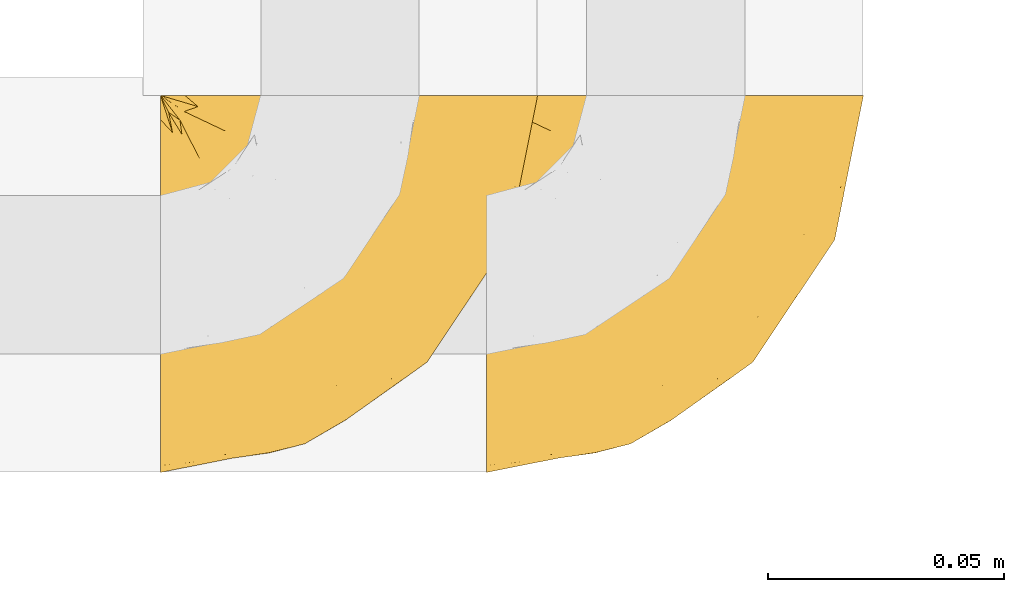
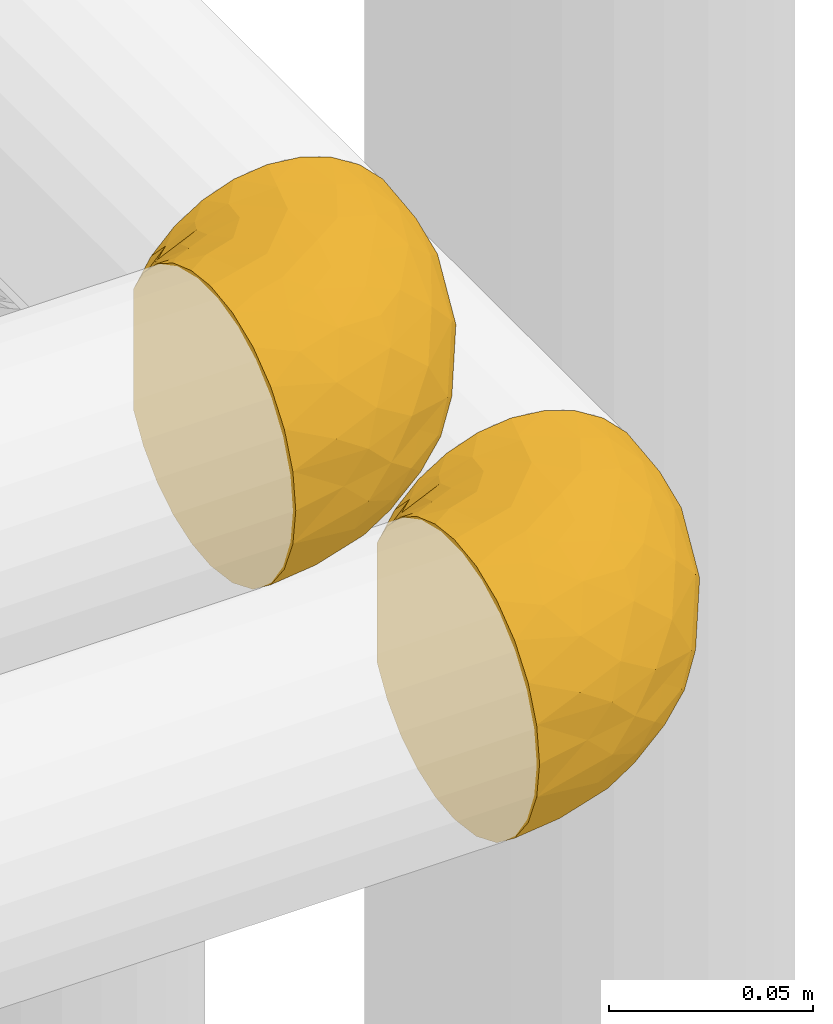
# One storey, part 448 of 827: 2 coverings.
"""IFC2X3 building model written with IfcOpenShell, lengths in millimetres."""

from ifc_helpers import new_model, entity, si_unit, converted_unit, derived_unit, direction, frame, origin, place, context, subcontext, project, spatial, faceted_brep, element, save


model = new_model("IFC2X3")

# Units and contexts
model_context = context("Model", 3, precision=0.01, world=origin(), true_north=direction((6.12303176911189e-17, 1.0)))
body_context = subcontext(model_context, "Body", "Model", "MODEL_VIEW")
ifc_project = project(units=[si_unit("LENGTHUNIT", "METRE", prefix="MILLI"), si_unit("AREAUNIT", "SQUARE_METRE"), si_unit("VOLUMEUNIT", "CUBIC_METRE"), converted_unit("PLANEANGLEUNIT", "DEGREE", entity("IfcRatioMeasure", 0.0174532925199433), si_unit("PLANEANGLEUNIT", "RADIAN"), dimensions=[0, 0, 0, 0, 0, 0, 0]), si_unit("MASSUNIT", "GRAM", prefix="KILO"), derived_unit("MASSDENSITYUNIT", [(si_unit("MASSUNIT", "GRAM", prefix="KILO"), 1), (si_unit("LENGTHUNIT", "METRE"), -3)]), derived_unit("MOMENTOFINERTIAUNIT", [(si_unit("LENGTHUNIT", "METRE"), 4)]), si_unit("TIMEUNIT", "SECOND"), si_unit("FREQUENCYUNIT", "HERTZ"), si_unit("THERMODYNAMICTEMPERATUREUNIT", "DEGREE_CELSIUS"), derived_unit("THERMALTRANSMITTANCEUNIT", [(si_unit("MASSUNIT", "GRAM", prefix="KILO"), 1), (si_unit("THERMODYNAMICTEMPERATUREUNIT", "KELVIN"), -1), (si_unit("TIMEUNIT", "SECOND"), -3)]), derived_unit("VOLUMETRICFLOWRATEUNIT", [(si_unit("LENGTHUNIT", "METRE"), 3), (si_unit("TIMEUNIT", "SECOND"), -1)]), derived_unit("MASSFLOWRATEUNIT", [(si_unit("MASSUNIT", "GRAM", prefix="KILO"), 1), (si_unit("TIMEUNIT", "SECOND"), -1)]), derived_unit("ROTATIONALFREQUENCYUNIT", [(si_unit("TIMEUNIT", "SECOND"), -1)]), si_unit("ELECTRICCURRENTUNIT", "AMPERE"), si_unit("ELECTRICVOLTAGEUNIT", "VOLT"), si_unit("POWERUNIT", "WATT"), si_unit("FORCEUNIT", "NEWTON", prefix="KILO"), si_unit("ILLUMINANCEUNIT", "LUX"), si_unit("LUMINOUSFLUXUNIT", "LUMEN"), si_unit("LUMINOUSINTENSITYUNIT", "CANDELA"), derived_unit("USERDEFINED", [(si_unit("MASSUNIT", "GRAM", prefix="KILO"), -1), (si_unit("LENGTHUNIT", "METRE"), -2), (si_unit("TIMEUNIT", "SECOND"), 3), (si_unit("LUMINOUSFLUXUNIT", "LUMEN"), 1)]), derived_unit("LINEARVELOCITYUNIT", [(si_unit("LENGTHUNIT", "METRE"), 1), (si_unit("TIMEUNIT", "SECOND"), -1)]), si_unit("PRESSUREUNIT", "PASCAL"), derived_unit("USERDEFINED", [(si_unit("LENGTHUNIT", "METRE"), -2), (si_unit("MASSUNIT", "GRAM", prefix="KILO"), 1), (si_unit("TIMEUNIT", "SECOND"), -2)]), derived_unit("LINEARFORCEUNIT", [(si_unit("MASSUNIT", "GRAM", prefix="KILO"), 1), (si_unit("LENGTHUNIT", "METRE"), 1), (si_unit("TIMEUNIT", "SECOND"), -2), (si_unit("LENGTHUNIT", "METRE"), -1)]), derived_unit("PLANARFORCEUNIT", [(si_unit("MASSUNIT", "GRAM", prefix="KILO"), 1), (si_unit("LENGTHUNIT", "METRE"), 1), (si_unit("TIMEUNIT", "SECOND"), -2), (si_unit("LENGTHUNIT", "METRE"), -2)])], contexts=[model_context])

# Site, building, storey
site_placement = place(None, origin())
site = spatial("IfcSite", under=ifc_project, at=site_placement, CompositionType="ELEMENT")
building_placement = place(site_placement, origin())
building = spatial("IfcBuilding", under=site, at=building_placement, CompositionType="ELEMENT")
storey_placement = place(building_placement, frame((0.0, 0.0, 28200.0)))
storey = spatial("IfcBuildingStorey", under=building, at=storey_placement, Name="08", CompositionType="ELEMENT", Elevation=28200.0)

# Coverings
covering_1_placement = place(storey_placement, frame((56593.63, 17185.12, 1356.55)))
element("IfcCovering", 1, at=covering_1_placement, inside=storey, Name=":ADSK_", ObjectType=":ADSK_", PredefinedType="INSULATION", context=body_context, shape_type="Brep", body=[
    faceted_brep([(57.76, 81.45, 81.15), (65.69, 81.45, 76.16), (72.32, 81.45, 69.53), (77.3, 81.45, 61.6), (80.4, 81.45, 52.75), (81.45, 81.45, 43.45), (80.39, 81.45, 34.13), (77.3, 81.45, 25.28), (72.31, 81.45, 17.35), (65.68, 81.45, 10.72), (57.75, 81.45, 5.74), (48.9, 81.45, 2.64), (39.6, 81.45, 1.6), (30.22, 81.45, 2.66), (21.33, 81.45, 5.79), (13.37, 81.45, 10.83), (6.73, 81.45, 17.53), (1.77, 81.45, 25.53), (1.77, 81.45, 26.45), (1.77, 81.45, 27.37), (1.77, 81.45, 28.17), (1.77, 81.45, 29.49), (1.77, 81.45, 30.81), (1.77, 81.45, 32.13), (1.77, 81.45, 33.45), (1.77, 81.45, 34.78), (1.77, 81.45, 36.1), (1.77, 81.45, 37.42), (1.77, 81.45, 38.74), (1.77, 81.45, 40.06), (1.77, 81.45, 41.38), (1.77, 81.45, 42.7), (1.77, 81.45, 44.02), (1.77, 81.45, 45.34), (1.77, 81.45, 46.66), (1.77, 81.45, 47.58), (1.77, 81.45, 48.5), (1.77, 81.45, 49.41), (1.77, 81.45, 50.33), (1.77, 81.45, 51.25), (1.77, 81.45, 52.17), (1.77, 81.45, 53.09), (1.77, 81.45, 54.01), (1.77, 81.45, 54.93), (1.77, 81.45, 55.85), (1.77, 81.45, 56.76), (1.77, 81.45, 57.68), (1.77, 81.45, 58.6), (1.77, 81.45, 59.52), (1.77, 81.45, 60.44), (1.77, 81.45, 61.36), (6.74, 81.45, 69.37), (13.38, 81.45, 76.07), (21.35, 81.45, 81.11), (30.24, 81.45, 84.24), (39.6, 81.45, 85.3), (48.91, 81.45, 84.24), (1.6, 76.3, 17.52), (1.6, 69.67, 10.83), (1.6, 61.7, 5.79), (1.6, 52.81, 2.66), (1.6, 43.45, 1.6), (1.6, 32.61, 3.02), (1.6, 22.52, 7.2), (1.6, 13.85, 13.85), (1.6, 7.2, 22.52), (1.6, 3.02, 32.61), (1.6, 1.6, 43.45), (1.6, 3.02, 54.28), (1.6, 7.2, 64.37), (1.6, 13.85, 73.04), (1.6, 22.52, 79.69), (1.6, 32.61, 83.87), (1.6, 43.45, 85.3), (1.6, 52.81, 84.23), (1.6, 61.7, 81.1), (1.6, 69.67, 76.06), (1.6, 76.3, 69.37), (1.6, 81.27, 61.36), (1.6, 81.27, 60.44), (1.6, 81.27, 59.12), (1.6, 81.27, 58.0), (1.6, 81.27, 56.88), (1.6, 81.27, 55.76), (1.6, 81.27, 54.64), (1.6, 81.27, 53.52), (1.6, 81.27, 52.4), (1.6, 81.27, 51.28), (1.6, 81.27, 50.16), (1.6, 81.27, 49.04), (1.6, 81.27, 47.92), (1.6, 81.27, 46.8), (1.6, 81.27, 45.68), (1.6, 81.27, 44.56), (1.6, 81.27, 43.45), (1.6, 81.27, 42.12), (1.6, 81.27, 40.8), (1.6, 81.27, 39.48), (1.6, 81.27, 38.16), (1.6, 81.27, 36.84), (1.6, 81.27, 35.52), (1.6, 81.27, 34.2), (1.6, 81.27, 32.88), (1.6, 81.27, 31.96), (1.6, 81.27, 31.05), (1.6, 81.27, 30.13), (1.6, 81.27, 29.21), (1.6, 81.27, 28.29), (1.6, 81.27, 27.37), (1.6, 81.27, 26.45), (1.6, 81.27, 25.53), (1.71, 81.31, 54.08), (1.73, 81.33, 55.16), (1.71, 81.31, 36.18), (1.72, 81.32, 35.13), (1.71, 81.31, 44.01), (1.72, 81.32, 45.08), (1.72, 81.32, 61.36), (1.72, 81.32, 59.98), (1.72, 81.32, 46.18), (1.72, 81.32, 26.74), (1.72, 81.32, 47.36), (1.72, 81.32, 29.67), (1.7, 81.3, 28.72), (1.72, 81.32, 39.77), (1.73, 81.33, 52.96), (1.72, 81.31, 51.84), (1.73, 81.33, 40.8), (1.73, 81.32, 41.87), (1.72, 81.32, 42.94), (1.72, 81.32, 27.77), (1.71, 81.31, 48.4), (1.72, 81.32, 37.21), (1.71, 81.31, 33.54), (1.72, 81.32, 32.49), (1.72, 81.32, 30.69), (1.72, 81.32, 50.69), (1.73, 81.33, 49.6), (1.72, 81.32, 56.32), (1.71, 81.31, 57.44), (1.73, 81.33, 58.88), (1.72, 81.32, 25.53), (1.74, 81.36, 61.36), (1.75, 81.4, 61.36), (1.75, 81.4, 25.53), (1.74, 81.36, 25.53), (1.64, 81.29, 61.36), (1.68, 81.3, 61.36), (1.68, 81.3, 25.53), (1.64, 81.29, 25.53), (1.74, 81.35, 31.59), (1.71, 81.31, 38.71), (8.98, 58.5, 3.97), (37.05, 71.95, 1.6), (24.69, 74.57, 3.97), (15.28, 73.93, 8.09), (16.86, 78.18, 8.09), (6.58, 78.04, 16.43), (5.71, 76.23, 15.73), (11.1, 45.99, 1.6), (10.79, 74.01, 10.79), (4.13, 73.57, 13.99), (6.62, 66.66, 8.08), (9.52, 79.09, 14.0), (6.14, 73.14, 12.83), (17.79, 60.34, 3.18), (20.6, 48.54, 1.6), (8.73, 45.36, 1.6), (23.66, 67.22, 3.28), (34.5, 62.45, 1.6), (15.32, 68.67, 6.28), (27.55, 55.49, 1.6), (3.31, 77.84, 19.06), (9.81, 68.16, 8.08), (37.68, 74.31, 1.6), (67.23, 38.78, 32.11), (76.64, 62.1, 29.62), (75.37, 50.89, 43.45), (14.58, 36.91, 2.45), (23.71, 40.37, 2.5), (34.34, 27.86, 9.73), (29.1, 15.77, 17.97), (18.02, 20.13, 10.24), (22.27, 31.54, 4.78), (10.97, 28.25, 4.78), (56.79, 57.26, 8.01), (60.76, 69.99, 8.01), (67.04, 64.58, 13.85), (36.11, 50.64, 2.42), (68.85, 51.97, 21.17), (24.58, 5.72, 35.73), (21.54, 7.42, 27.43), (78.4, 66.14, 43.45), (14.11, 11.35, 17.97), (53.42, 21.64, 35.71), (58.19, 28.57, 29.47), (44.49, 55.38, 3.41), (51.77, 68.51, 3.94), (73.69, 67.48, 21.17), (45.89, 40.78, 7.92), (35.97, 41.53, 4.25), (56.55, 46.11, 11.75), (60.03, 40.32, 18.31), (63.64, 38.36, 24.94), (34.98, 11.84, 28.78), (40.58, 12.56, 35.82), (32.15, 7.67, 43.45), (47.26, 19.39, 28.38), (58.06, 24.98, 43.45), (66.71, 37.94, 43.45), (16.9, 4.64, 43.45), (52.08, 28.09, 21.21), (41.21, 23.73, 16.48), (49.76, 34.03, 13.85), (45.11, 16.33, 43.45), (15.65, 29.29, 82.11), (24.57, 5.77, 51.41), (50.54, 21.44, 57.45), (67.25, 38.8, 54.78), (67.06, 64.58, 73.03), (73.7, 67.49, 65.7), (26.13, 22.9, 76.65), (19.54, 12.54, 68.92), (38.96, 20.04, 68.01), (56.8, 57.26, 78.88), (60.77, 69.99, 78.88), (51.78, 68.51, 82.94), (59.09, 34.54, 64.44), (19.25, 38.81, 84.49), (20.6, 48.54, 85.3), (11.1, 45.99, 85.3), (37.68, 74.31, 85.3), (15.21, 5.36, 57.84), (12.76, 18.96, 76.65), (40.93, 12.79, 51.19), (76.65, 62.11, 57.26), (39.5, 33.14, 78.14), (25.01, 33.44, 82.35), (68.86, 51.98, 65.7), (26.7, 43.42, 84.61), (34.95, 48.62, 84.36), (34.5, 62.45, 85.3), (27.55, 55.49, 85.3), (61.27, 49.68, 73.03), (44.5, 55.37, 83.48), (37.05, 71.95, 85.3), (10.25, 36.37, 84.54), (49.78, 34.04, 73.03), (47.51, 44.1, 79.54), (29.38, 9.99, 59.46), (40.01, 26.41, 73.5), (33.36, 39.19, 82.57), (8.98, 58.5, 82.92), (23.67, 67.22, 83.62), (24.71, 74.57, 82.92), (15.29, 73.92, 78.81), (4.13, 73.57, 72.9), (6.14, 73.14, 74.06), (4.96, 66.19, 78.81), (9.81, 68.16, 78.81), (3.31, 77.84, 67.83), (5.7, 76.23, 71.15), (9.53, 79.08, 72.91), (6.59, 78.04, 70.47), (16.63, 77.18, 78.81), (15.34, 68.66, 80.62), (10.8, 74.0, 76.11), (17.79, 60.34, 83.71)], [[[0, 1, 2, 3, 4, 5, 6, 7, 8, 9, 10, 11, 12, 13, 14, 15, 16, 17, 18, 19, 20, 21, 22, 23, 24, 25, 26, 27, 28, 29, 30, 31, 32, 33, 34, 35, 36, 37, 38, 39, 40, 41, 42, 43, 44, 45, 46, 47, 48, 49, 50, 51, 52, 53, 54, 55, 56]], [[57, 58, 59, 60, 61, 62, 63, 64, 65, 66, 67, 68, 69, 70, 71, 72, 73, 74, 75, 76, 77, 78, 79, 80, 81, 82, 83, 84, 85, 86, 87, 88, 89, 90, 91, 92, 93, 94, 95, 96, 97, 98, 99, 100, 101, 102, 103, 104, 105, 106, 107, 108, 109, 110]], [[111, 84, 112]], [[113, 26, 114]], [[114, 101, 100]], [[115, 93, 116]], [[79, 117, 118]], [[33, 116, 119]], [[117, 49, 118]], [[19, 18, 120]], [[119, 121, 34]], [[122, 21, 123]], [[97, 96, 124]], [[86, 125, 126]], [[116, 92, 119]], [[127, 96, 128]], [[32, 129, 115]], [[19, 120, 130]], [[121, 90, 131]], [[94, 115, 129]], [[115, 116, 32]], [[118, 49, 48]], [[113, 99, 132]], [[133, 114, 25]], [[24, 134, 133]], [[135, 22, 122]], [[136, 137, 88]], [[84, 83, 112]], [[138, 82, 139]], [[130, 20, 19]], [[118, 48, 140]], [[81, 140, 139]], [[123, 21, 20]], [[141, 120, 18]], [[139, 82, 81]], [[130, 107, 123]], [[49, 117, 142, 143, 50]], [[18, 17, 144, 145, 141]], [[79, 78, 146, 147, 117]], [[109, 141, 148, 149, 110]], [[102, 133, 134]], [[105, 135, 122]], [[118, 80, 79]], [[80, 118, 140]], [[120, 109, 108]], [[47, 46, 140, 48]], [[81, 80, 140]], [[44, 112, 138]], [[93, 115, 94]], [[46, 139, 140]], [[46, 45, 139]], [[139, 45, 138]], [[138, 112, 83]], [[85, 84, 111]], [[112, 43, 111]], [[83, 82, 138]], [[106, 122, 123]], [[105, 122, 106]], [[21, 122, 22]], [[124, 29, 28]], [[33, 32, 116]], [[128, 129, 31]], [[32, 31, 129]], [[34, 33, 119]], [[116, 93, 92]], [[129, 95, 94]], [[95, 129, 128]], [[41, 40, 125, 42]], [[119, 91, 121]], [[36, 35, 131, 37]], [[137, 131, 89]], [[121, 131, 35]], [[90, 121, 91]], [[119, 92, 91]], [[136, 126, 39]], [[125, 86, 85]], [[42, 125, 111]], [[85, 111, 125]], [[150, 23, 22]], [[130, 108, 107]], [[130, 123, 20]], [[107, 106, 123]], [[137, 37, 131]], [[136, 38, 137]], [[89, 88, 137]], [[131, 90, 89]], [[124, 151, 97]], [[40, 39, 126]], [[87, 126, 136]], [[86, 126, 87]], [[136, 88, 87]], [[40, 126, 125]], [[39, 38, 136]], [[95, 128, 96]], [[30, 128, 31]], [[29, 124, 127]], [[127, 128, 30]], [[151, 124, 28]], [[127, 30, 29]], [[127, 124, 96]], [[151, 98, 97]], [[45, 44, 138]], [[26, 113, 132]], [[113, 100, 99]], [[132, 151, 27]], [[27, 26, 132]], [[26, 25, 114]], [[100, 113, 114]], [[101, 133, 102]], [[133, 101, 114]], [[28, 27, 151]], [[132, 99, 98]], [[23, 134, 24]], [[25, 24, 133]], [[134, 23, 150]], [[135, 104, 150]], [[150, 104, 103]], [[103, 102, 134]], [[130, 120, 108]], [[109, 120, 141]], [[42, 111, 43]], [[112, 44, 43]], [[104, 135, 105]], [[134, 150, 103]], [[135, 150, 22]], [[35, 34, 121]], [[137, 38, 37]], [[98, 151, 132]], [[59, 152, 60]], [[13, 153, 154]], [[155, 156, 154]], [[157, 158, 141]], [[159, 60, 152]], [[160, 157, 155]], [[161, 162, 58]], [[58, 162, 59]], [[144, 16, 163]], [[58, 57, 161]], [[162, 161, 164]], [[157, 163, 155]], [[163, 16, 15]], [[57, 149, 161]], [[152, 165, 166]], [[157, 144, 163]], [[60, 159, 167, 61]], [[156, 14, 154]], [[163, 156, 155]], [[155, 154, 168]], [[168, 154, 169]], [[155, 170, 160]], [[57, 110, 149]], [[144, 17, 16]], [[156, 15, 14]], [[171, 165, 168]], [[158, 164, 172]], [[14, 13, 154]], [[157, 141, 145, 144]], [[173, 164, 158]], [[173, 160, 170]], [[171, 166, 165]], [[168, 165, 170]], [[168, 169, 171]], [[152, 173, 165]], [[170, 155, 168]], [[165, 173, 170]], [[160, 173, 158]], [[172, 149, 148]], [[148, 141, 158]], [[158, 157, 160]], [[152, 166, 159]], [[173, 152, 162]], [[59, 162, 152]], [[13, 12, 174, 153]], [[153, 169, 154]], [[15, 156, 163]], [[162, 164, 173]], [[172, 164, 161]], [[149, 172, 161]], [[158, 172, 148]], [[175, 176, 177]], [[178, 166, 179]], [[180, 181, 182]], [[183, 184, 178]], [[185, 186, 187]], [[171, 188, 179]], [[174, 12, 11]], [[189, 176, 175]], [[190, 66, 191]], [[176, 6, 192]], [[193, 65, 64]], [[63, 184, 182]], [[63, 182, 64]], [[65, 193, 191]], [[184, 63, 62]], [[175, 194, 195]], [[196, 169, 197]], [[174, 11, 197]], [[8, 7, 198]], [[187, 9, 8]], [[197, 169, 153, 174]], [[197, 11, 10]], [[186, 197, 10]], [[199, 180, 200]], [[197, 185, 196]], [[201, 189, 202]], [[201, 187, 189]], [[195, 203, 175]], [[191, 204, 190]], [[176, 7, 6]], [[177, 176, 192]], [[189, 198, 176]], [[65, 191, 66]], [[198, 187, 8]], [[205, 206, 190]], [[9, 186, 10]], [[181, 207, 204]], [[208, 175, 177, 209]], [[66, 190, 210]], [[211, 212, 213]], [[190, 204, 205]], [[180, 182, 183]], [[193, 182, 181]], [[62, 61, 167]], [[196, 185, 199]], [[196, 200, 188]], [[6, 5, 192]], [[176, 198, 7]], [[187, 198, 189]], [[187, 186, 9]], [[197, 186, 185]], [[200, 180, 183]], [[180, 213, 212]], [[179, 183, 178]], [[185, 201, 199]], [[210, 190, 206]], [[210, 67, 66]], [[205, 204, 207]], [[194, 205, 207]], [[194, 214, 205]], [[195, 194, 207]], [[208, 194, 175]], [[207, 211, 195]], [[202, 203, 211]], [[212, 207, 181]], [[202, 211, 213]], [[201, 202, 213]], [[189, 175, 203]], [[199, 201, 213]], [[187, 201, 185]], [[180, 199, 213]], [[196, 199, 200]], [[211, 203, 195]], [[189, 203, 202]], [[207, 212, 211]], [[180, 212, 181]], [[214, 194, 208]], [[214, 206, 205]], [[196, 188, 169]], [[181, 204, 191]], [[182, 193, 64]], [[191, 193, 181]], [[178, 62, 167]], [[182, 184, 183]], [[62, 178, 184]], [[178, 167, 159, 166]], [[171, 179, 166]], [[200, 183, 179]], [[179, 188, 200]], [[169, 188, 171]], [[71, 215, 72]], [[206, 216, 210]], [[217, 208, 218]], [[216, 68, 210]], [[219, 220, 2]], [[221, 222, 223]], [[224, 225, 226]], [[227, 223, 217]], [[228, 229, 230]], [[56, 231, 226]], [[232, 222, 69]], [[56, 55, 231]], [[70, 233, 71]], [[71, 233, 215]], [[0, 56, 226]], [[208, 217, 234]], [[218, 177, 235]], [[221, 236, 237]], [[238, 220, 219]], [[1, 219, 2]], [[68, 216, 232]], [[235, 3, 220]], [[235, 192, 4]], [[1, 0, 225]], [[228, 239, 229]], [[240, 241, 242]], [[243, 238, 219]], [[224, 226, 244]], [[226, 241, 244]], [[3, 235, 4]], [[69, 222, 70]], [[225, 219, 1]], [[218, 235, 238]], [[243, 219, 224]], [[218, 227, 217]], [[3, 2, 220]], [[218, 208, 209, 177]], [[226, 231, 245, 241]], [[215, 228, 246]], [[247, 248, 236]], [[248, 224, 244]], [[223, 222, 249]], [[233, 222, 221]], [[242, 239, 240]], [[248, 247, 243]], [[217, 223, 249]], [[250, 247, 236]], [[216, 234, 249]], [[218, 238, 227]], [[192, 235, 177]], [[192, 5, 4]], [[72, 246, 73]], [[235, 220, 238]], [[226, 225, 0]], [[219, 225, 224]], [[240, 248, 244]], [[239, 242, 229]], [[236, 248, 251]], [[68, 67, 210]], [[234, 216, 206]], [[216, 249, 232]], [[234, 206, 214, 208]], [[249, 234, 217]], [[222, 232, 249]], [[69, 68, 232]], [[246, 228, 230]], [[237, 228, 215]], [[243, 227, 238]], [[223, 227, 247]], [[73, 246, 230]], [[215, 246, 72]], [[248, 243, 224]], [[227, 243, 247]], [[237, 236, 251]], [[250, 221, 223]], [[222, 233, 70]], [[215, 233, 221]], [[221, 237, 215]], [[239, 237, 251]], [[237, 239, 228]], [[239, 251, 240]], [[248, 240, 251]], [[241, 240, 244]], [[221, 250, 236]], [[223, 247, 250]], [[74, 230, 252]], [[253, 254, 255]], [[146, 77, 256]], [[257, 258, 259]], [[260, 256, 257]], [[260, 261, 147]], [[75, 74, 252]], [[51, 143, 262]], [[263, 143, 142, 117]], [[256, 77, 76]], [[252, 258, 75]], [[253, 241, 254]], [[254, 245, 54]], [[258, 256, 76]], [[53, 52, 264]], [[255, 265, 253]], [[254, 264, 255]], [[255, 264, 262]], [[75, 258, 76]], [[265, 255, 266]], [[255, 262, 263]], [[51, 50, 143]], [[54, 245, 231, 55]], [[51, 262, 52]], [[253, 267, 242]], [[254, 54, 53]], [[266, 259, 265]], [[146, 78, 77]], [[263, 117, 261]], [[146, 256, 260]], [[257, 259, 261]], [[267, 253, 265]], [[229, 267, 252]], [[242, 267, 229]], [[242, 241, 253]], [[252, 267, 259]], [[255, 263, 266]], [[259, 267, 265]], [[261, 117, 147]], [[263, 261, 266]], [[259, 266, 261]], [[230, 74, 73]], [[230, 229, 252]], [[259, 258, 252]], [[254, 241, 245]], [[53, 264, 254]], [[52, 262, 264]], [[143, 263, 262]], [[258, 257, 256]], [[261, 260, 257]], [[146, 260, 147]]]),
])
covering_2_placement = place(storey_placement, frame((56524.63, 17185.12, 1456.55)))
element("IfcCovering", 2, at=covering_2_placement, inside=storey, Name=":ADSK_", ObjectType=":ADSK_", PredefinedType="INSULATION", context=body_context, shape_type="Brep", body=[
    faceted_brep([(57.76, 81.45, 81.15), (65.69, 81.45, 76.16), (72.32, 81.45, 69.53), (77.3, 81.45, 61.6), (80.4, 81.45, 52.75), (81.45, 81.45, 43.45), (80.39, 81.45, 34.13), (77.3, 81.45, 25.28), (72.31, 81.45, 17.35), (65.68, 81.45, 10.72), (57.75, 81.45, 5.74), (48.9, 81.45, 2.64), (39.6, 81.45, 1.6), (30.22, 81.45, 2.66), (21.33, 81.45, 5.79), (13.37, 81.45, 10.83), (6.73, 81.45, 17.53), (1.77, 81.45, 25.53), (1.77, 81.45, 26.45), (1.77, 81.45, 27.37), (1.77, 81.45, 28.17), (1.77, 81.45, 29.49), (1.77, 81.45, 30.81), (1.77, 81.45, 32.13), (1.77, 81.45, 33.45), (1.77, 81.45, 34.78), (1.77, 81.45, 36.1), (1.77, 81.45, 37.42), (1.77, 81.45, 38.74), (1.77, 81.45, 40.06), (1.77, 81.45, 41.38), (1.77, 81.45, 42.7), (1.77, 81.45, 44.02), (1.77, 81.45, 45.34), (1.77, 81.45, 46.66), (1.77, 81.45, 47.58), (1.77, 81.45, 48.5), (1.77, 81.45, 49.41), (1.77, 81.45, 50.33), (1.77, 81.45, 51.25), (1.77, 81.45, 52.17), (1.77, 81.45, 53.09), (1.77, 81.45, 54.01), (1.77, 81.45, 54.93), (1.77, 81.45, 55.85), (1.77, 81.45, 56.76), (1.77, 81.45, 57.68), (1.77, 81.45, 58.6), (1.77, 81.45, 59.52), (1.77, 81.45, 60.44), (1.77, 81.45, 61.36), (6.74, 81.45, 69.37), (13.38, 81.45, 76.07), (21.35, 81.45, 81.11), (30.24, 81.45, 84.24), (39.6, 81.45, 85.3), (48.91, 81.45, 84.24), (1.6, 76.3, 17.52), (1.6, 69.67, 10.83), (1.6, 61.7, 5.79), (1.6, 52.81, 2.66), (1.6, 43.45, 1.6), (1.6, 32.61, 3.02), (1.6, 22.52, 7.2), (1.6, 13.85, 13.85), (1.6, 7.2, 22.52), (1.6, 3.02, 32.61), (1.6, 1.6, 43.45), (1.6, 3.02, 54.28), (1.6, 7.2, 64.37), (1.6, 13.85, 73.04), (1.6, 22.52, 79.69), (1.6, 32.61, 83.87), (1.6, 43.45, 85.3), (1.6, 52.81, 84.23), (1.6, 61.7, 81.1), (1.6, 69.67, 76.06), (1.6, 76.3, 69.37), (1.6, 81.27, 61.36), (1.6, 81.27, 60.44), (1.6, 81.27, 59.12), (1.6, 81.27, 58.0), (1.6, 81.27, 56.88), (1.6, 81.27, 55.76), (1.6, 81.27, 54.64), (1.6, 81.27, 53.52), (1.6, 81.27, 52.4), (1.6, 81.27, 51.28), (1.6, 81.27, 50.16), (1.6, 81.27, 49.04), (1.6, 81.27, 47.92), (1.6, 81.27, 46.8), (1.6, 81.27, 45.68), (1.6, 81.27, 44.56), (1.6, 81.27, 43.45), (1.6, 81.27, 42.12), (1.6, 81.27, 40.8), (1.6, 81.27, 39.48), (1.6, 81.27, 38.16), (1.6, 81.27, 36.84), (1.6, 81.27, 35.52), (1.6, 81.27, 34.2), (1.6, 81.27, 32.88), (1.6, 81.27, 31.96), (1.6, 81.27, 31.05), (1.6, 81.27, 30.13), (1.6, 81.27, 29.21), (1.6, 81.27, 28.29), (1.6, 81.27, 27.37), (1.6, 81.27, 26.45), (1.6, 81.27, 25.53), (1.71, 81.31, 54.08), (1.73, 81.33, 55.16), (1.71, 81.31, 36.18), (1.72, 81.32, 35.13), (1.71, 81.31, 44.01), (1.72, 81.32, 45.08), (1.72, 81.32, 61.36), (1.72, 81.32, 59.98), (1.72, 81.32, 46.18), (1.72, 81.32, 26.74), (1.72, 81.32, 47.36), (1.72, 81.32, 29.67), (1.7, 81.3, 28.72), (1.72, 81.32, 39.77), (1.73, 81.33, 52.96), (1.72, 81.31, 51.84), (1.73, 81.33, 40.8), (1.73, 81.32, 41.87), (1.72, 81.32, 42.94), (1.72, 81.32, 27.77), (1.71, 81.31, 48.4), (1.72, 81.32, 37.21), (1.71, 81.31, 33.54), (1.72, 81.32, 32.49), (1.72, 81.32, 30.69), (1.72, 81.32, 50.69), (1.73, 81.33, 49.6), (1.72, 81.32, 56.32), (1.71, 81.31, 57.44), (1.73, 81.33, 58.88), (1.72, 81.32, 25.53), (1.74, 81.36, 61.36), (1.75, 81.4, 61.36), (1.75, 81.4, 25.53), (1.74, 81.36, 25.53), (1.64, 81.29, 61.36), (1.68, 81.3, 61.36), (1.68, 81.3, 25.53), (1.64, 81.29, 25.53), (1.74, 81.35, 31.59), (1.71, 81.31, 38.71), (8.98, 58.5, 3.97), (37.05, 71.95, 1.6), (24.69, 74.57, 3.97), (15.28, 73.93, 8.09), (16.86, 78.18, 8.09), (6.58, 78.04, 16.43), (5.71, 76.23, 15.73), (11.1, 45.99, 1.6), (10.79, 74.01, 10.79), (4.13, 73.57, 13.99), (6.62, 66.66, 8.08), (9.52, 79.09, 14.0), (6.14, 73.14, 12.83), (17.79, 60.34, 3.18), (20.6, 48.54, 1.6), (8.73, 45.36, 1.6), (23.66, 67.22, 3.28), (34.5, 62.45, 1.6), (15.32, 68.67, 6.28), (27.55, 55.49, 1.6), (3.31, 77.84, 19.06), (9.81, 68.16, 8.08), (37.68, 74.31, 1.6), (67.23, 38.78, 32.11), (76.64, 62.1, 29.62), (75.37, 50.89, 43.45), (14.58, 36.91, 2.45), (23.71, 40.37, 2.5), (34.34, 27.86, 9.73), (29.1, 15.77, 17.97), (18.02, 20.13, 10.24), (22.27, 31.54, 4.78), (10.97, 28.25, 4.78), (56.79, 57.26, 8.01), (60.76, 69.99, 8.01), (67.04, 64.58, 13.85), (36.11, 50.64, 2.42), (68.85, 51.97, 21.17), (24.58, 5.72, 35.73), (21.54, 7.42, 27.43), (78.4, 66.14, 43.45), (14.11, 11.35, 17.97), (53.42, 21.64, 35.71), (58.19, 28.57, 29.47), (44.49, 55.38, 3.41), (51.77, 68.51, 3.94), (73.69, 67.48, 21.17), (45.89, 40.78, 7.92), (35.97, 41.53, 4.25), (56.55, 46.11, 11.75), (60.03, 40.32, 18.31), (63.64, 38.36, 24.94), (34.98, 11.84, 28.78), (40.58, 12.56, 35.82), (32.15, 7.67, 43.45), (47.26, 19.39, 28.38), (58.06, 24.98, 43.45), (66.71, 37.94, 43.45), (16.9, 4.64, 43.45), (52.08, 28.09, 21.21), (41.21, 23.73, 16.48), (49.76, 34.03, 13.85), (45.11, 16.33, 43.45), (15.65, 29.29, 82.11), (24.57, 5.77, 51.41), (50.54, 21.44, 57.45), (67.25, 38.8, 54.78), (67.06, 64.58, 73.03), (73.7, 67.49, 65.7), (26.13, 22.9, 76.65), (19.54, 12.54, 68.92), (38.96, 20.04, 68.01), (56.8, 57.26, 78.88), (60.77, 69.99, 78.88), (51.78, 68.51, 82.94), (59.09, 34.54, 64.44), (19.25, 38.81, 84.49), (20.6, 48.54, 85.3), (11.1, 45.99, 85.3), (37.68, 74.31, 85.3), (15.21, 5.36, 57.84), (12.76, 18.96, 76.65), (40.93, 12.79, 51.19), (76.65, 62.11, 57.26), (39.5, 33.14, 78.14), (25.01, 33.44, 82.35), (68.86, 51.98, 65.7), (26.7, 43.42, 84.61), (34.95, 48.62, 84.36), (34.5, 62.45, 85.3), (27.55, 55.49, 85.3), (61.27, 49.68, 73.03), (44.5, 55.37, 83.48), (37.05, 71.95, 85.3), (10.25, 36.37, 84.54), (49.78, 34.04, 73.03), (47.51, 44.1, 79.54), (29.38, 9.99, 59.46), (40.01, 26.41, 73.5), (33.36, 39.19, 82.57), (8.98, 58.5, 82.92), (23.67, 67.22, 83.62), (24.71, 74.57, 82.92), (15.29, 73.92, 78.81), (4.13, 73.57, 72.9), (6.14, 73.14, 74.06), (4.96, 66.19, 78.81), (9.81, 68.16, 78.81), (3.31, 77.84, 67.83), (5.7, 76.23, 71.15), (9.53, 79.08, 72.91), (6.59, 78.04, 70.47), (16.63, 77.18, 78.81), (15.34, 68.66, 80.62), (10.8, 74.0, 76.11), (17.79, 60.34, 83.71)], [[[0, 1, 2, 3, 4, 5, 6, 7, 8, 9, 10, 11, 12, 13, 14, 15, 16, 17, 18, 19, 20, 21, 22, 23, 24, 25, 26, 27, 28, 29, 30, 31, 32, 33, 34, 35, 36, 37, 38, 39, 40, 41, 42, 43, 44, 45, 46, 47, 48, 49, 50, 51, 52, 53, 54, 55, 56]], [[57, 58, 59, 60, 61, 62, 63, 64, 65, 66, 67, 68, 69, 70, 71, 72, 73, 74, 75, 76, 77, 78, 79, 80, 81, 82, 83, 84, 85, 86, 87, 88, 89, 90, 91, 92, 93, 94, 95, 96, 97, 98, 99, 100, 101, 102, 103, 104, 105, 106, 107, 108, 109, 110]], [[111, 84, 112]], [[113, 26, 114]], [[114, 101, 100]], [[115, 93, 116]], [[79, 117, 118]], [[33, 116, 119]], [[117, 49, 118]], [[19, 18, 120]], [[119, 121, 34]], [[122, 21, 123]], [[97, 96, 124]], [[86, 125, 126]], [[116, 92, 119]], [[127, 96, 128]], [[32, 129, 115]], [[19, 120, 130]], [[121, 90, 131]], [[94, 115, 129]], [[115, 116, 32]], [[118, 49, 48]], [[113, 99, 132]], [[133, 114, 25]], [[24, 134, 133]], [[135, 22, 122]], [[136, 137, 88]], [[84, 83, 112]], [[138, 82, 139]], [[130, 20, 19]], [[118, 48, 140]], [[81, 140, 139]], [[123, 21, 20]], [[141, 120, 18]], [[139, 82, 81]], [[130, 107, 123]], [[49, 117, 142, 143, 50]], [[18, 17, 144, 145, 141]], [[79, 78, 146, 147, 117]], [[109, 141, 148, 149, 110]], [[102, 133, 134]], [[105, 135, 122]], [[118, 80, 79]], [[80, 118, 140]], [[120, 109, 108]], [[47, 46, 140, 48]], [[81, 80, 140]], [[44, 112, 138]], [[93, 115, 94]], [[46, 139, 140]], [[46, 45, 139]], [[139, 45, 138]], [[138, 112, 83]], [[85, 84, 111]], [[112, 43, 111]], [[83, 82, 138]], [[106, 122, 123]], [[105, 122, 106]], [[21, 122, 22]], [[124, 29, 28]], [[33, 32, 116]], [[128, 129, 31]], [[32, 31, 129]], [[34, 33, 119]], [[116, 93, 92]], [[129, 95, 94]], [[95, 129, 128]], [[41, 40, 125, 42]], [[119, 91, 121]], [[36, 35, 131, 37]], [[137, 131, 89]], [[121, 131, 35]], [[90, 121, 91]], [[119, 92, 91]], [[136, 126, 39]], [[125, 86, 85]], [[42, 125, 111]], [[85, 111, 125]], [[150, 23, 22]], [[130, 108, 107]], [[130, 123, 20]], [[107, 106, 123]], [[137, 37, 131]], [[136, 38, 137]], [[89, 88, 137]], [[131, 90, 89]], [[124, 151, 97]], [[40, 39, 126]], [[87, 126, 136]], [[86, 126, 87]], [[136, 88, 87]], [[40, 126, 125]], [[39, 38, 136]], [[95, 128, 96]], [[30, 128, 31]], [[29, 124, 127]], [[127, 128, 30]], [[151, 124, 28]], [[127, 30, 29]], [[127, 124, 96]], [[151, 98, 97]], [[45, 44, 138]], [[26, 113, 132]], [[113, 100, 99]], [[132, 151, 27]], [[27, 26, 132]], [[26, 25, 114]], [[100, 113, 114]], [[101, 133, 102]], [[133, 101, 114]], [[28, 27, 151]], [[132, 99, 98]], [[23, 134, 24]], [[25, 24, 133]], [[134, 23, 150]], [[135, 104, 150]], [[150, 104, 103]], [[103, 102, 134]], [[130, 120, 108]], [[109, 120, 141]], [[42, 111, 43]], [[112, 44, 43]], [[104, 135, 105]], [[134, 150, 103]], [[135, 150, 22]], [[35, 34, 121]], [[137, 38, 37]], [[98, 151, 132]], [[59, 152, 60]], [[13, 153, 154]], [[155, 156, 154]], [[157, 158, 141]], [[159, 60, 152]], [[160, 157, 155]], [[161, 162, 58]], [[58, 162, 59]], [[144, 16, 163]], [[58, 57, 161]], [[162, 161, 164]], [[157, 163, 155]], [[163, 16, 15]], [[57, 149, 161]], [[152, 165, 166]], [[157, 144, 163]], [[60, 159, 167, 61]], [[156, 14, 154]], [[163, 156, 155]], [[155, 154, 168]], [[168, 154, 169]], [[155, 170, 160]], [[57, 110, 149]], [[144, 17, 16]], [[156, 15, 14]], [[171, 165, 168]], [[158, 164, 172]], [[14, 13, 154]], [[157, 141, 145, 144]], [[173, 164, 158]], [[173, 160, 170]], [[171, 166, 165]], [[168, 165, 170]], [[168, 169, 171]], [[152, 173, 165]], [[170, 155, 168]], [[165, 173, 170]], [[160, 173, 158]], [[172, 149, 148]], [[148, 141, 158]], [[158, 157, 160]], [[152, 166, 159]], [[173, 152, 162]], [[59, 162, 152]], [[13, 12, 174, 153]], [[153, 169, 154]], [[15, 156, 163]], [[162, 164, 173]], [[172, 164, 161]], [[149, 172, 161]], [[158, 172, 148]], [[175, 176, 177]], [[178, 166, 179]], [[180, 181, 182]], [[183, 184, 178]], [[185, 186, 187]], [[171, 188, 179]], [[174, 12, 11]], [[189, 176, 175]], [[190, 66, 191]], [[176, 6, 192]], [[193, 65, 64]], [[63, 184, 182]], [[63, 182, 64]], [[65, 193, 191]], [[184, 63, 62]], [[175, 194, 195]], [[196, 169, 197]], [[174, 11, 197]], [[8, 7, 198]], [[187, 9, 8]], [[197, 169, 153, 174]], [[197, 11, 10]], [[186, 197, 10]], [[199, 180, 200]], [[197, 185, 196]], [[201, 189, 202]], [[201, 187, 189]], [[195, 203, 175]], [[191, 204, 190]], [[176, 7, 6]], [[177, 176, 192]], [[189, 198, 176]], [[65, 191, 66]], [[198, 187, 8]], [[205, 206, 190]], [[9, 186, 10]], [[181, 207, 204]], [[208, 175, 177, 209]], [[66, 190, 210]], [[211, 212, 213]], [[190, 204, 205]], [[180, 182, 183]], [[193, 182, 181]], [[62, 61, 167]], [[196, 185, 199]], [[196, 200, 188]], [[6, 5, 192]], [[176, 198, 7]], [[187, 198, 189]], [[187, 186, 9]], [[197, 186, 185]], [[200, 180, 183]], [[180, 213, 212]], [[179, 183, 178]], [[185, 201, 199]], [[210, 190, 206]], [[210, 67, 66]], [[205, 204, 207]], [[194, 205, 207]], [[194, 214, 205]], [[195, 194, 207]], [[208, 194, 175]], [[207, 211, 195]], [[202, 203, 211]], [[212, 207, 181]], [[202, 211, 213]], [[201, 202, 213]], [[189, 175, 203]], [[199, 201, 213]], [[187, 201, 185]], [[180, 199, 213]], [[196, 199, 200]], [[211, 203, 195]], [[189, 203, 202]], [[207, 212, 211]], [[180, 212, 181]], [[214, 194, 208]], [[214, 206, 205]], [[196, 188, 169]], [[181, 204, 191]], [[182, 193, 64]], [[191, 193, 181]], [[178, 62, 167]], [[182, 184, 183]], [[62, 178, 184]], [[178, 167, 159, 166]], [[171, 179, 166]], [[200, 183, 179]], [[179, 188, 200]], [[169, 188, 171]], [[71, 215, 72]], [[206, 216, 210]], [[217, 208, 218]], [[216, 68, 210]], [[219, 220, 2]], [[221, 222, 223]], [[224, 225, 226]], [[227, 223, 217]], [[228, 229, 230]], [[56, 231, 226]], [[232, 222, 69]], [[56, 55, 231]], [[70, 233, 71]], [[71, 233, 215]], [[0, 56, 226]], [[208, 217, 234]], [[218, 177, 235]], [[221, 236, 237]], [[238, 220, 219]], [[1, 219, 2]], [[68, 216, 232]], [[235, 3, 220]], [[235, 192, 4]], [[1, 0, 225]], [[228, 239, 229]], [[240, 241, 242]], [[243, 238, 219]], [[224, 226, 244]], [[226, 241, 244]], [[3, 235, 4]], [[69, 222, 70]], [[225, 219, 1]], [[218, 235, 238]], [[243, 219, 224]], [[218, 227, 217]], [[3, 2, 220]], [[218, 208, 209, 177]], [[226, 231, 245, 241]], [[215, 228, 246]], [[247, 248, 236]], [[248, 224, 244]], [[223, 222, 249]], [[233, 222, 221]], [[242, 239, 240]], [[248, 247, 243]], [[217, 223, 249]], [[250, 247, 236]], [[216, 234, 249]], [[218, 238, 227]], [[192, 235, 177]], [[192, 5, 4]], [[72, 246, 73]], [[235, 220, 238]], [[226, 225, 0]], [[219, 225, 224]], [[240, 248, 244]], [[239, 242, 229]], [[236, 248, 251]], [[68, 67, 210]], [[234, 216, 206]], [[216, 249, 232]], [[234, 206, 214, 208]], [[249, 234, 217]], [[222, 232, 249]], [[69, 68, 232]], [[246, 228, 230]], [[237, 228, 215]], [[243, 227, 238]], [[223, 227, 247]], [[73, 246, 230]], [[215, 246, 72]], [[248, 243, 224]], [[227, 243, 247]], [[237, 236, 251]], [[250, 221, 223]], [[222, 233, 70]], [[215, 233, 221]], [[221, 237, 215]], [[239, 237, 251]], [[237, 239, 228]], [[239, 251, 240]], [[248, 240, 251]], [[241, 240, 244]], [[221, 250, 236]], [[223, 247, 250]], [[74, 230, 252]], [[253, 254, 255]], [[146, 77, 256]], [[257, 258, 259]], [[260, 256, 257]], [[260, 261, 147]], [[75, 74, 252]], [[51, 143, 262]], [[263, 143, 142, 117]], [[256, 77, 76]], [[252, 258, 75]], [[253, 241, 254]], [[254, 245, 54]], [[258, 256, 76]], [[53, 52, 264]], [[255, 265, 253]], [[254, 264, 255]], [[255, 264, 262]], [[75, 258, 76]], [[265, 255, 266]], [[255, 262, 263]], [[51, 50, 143]], [[54, 245, 231, 55]], [[51, 262, 52]], [[253, 267, 242]], [[254, 54, 53]], [[266, 259, 265]], [[146, 78, 77]], [[263, 117, 261]], [[146, 256, 260]], [[257, 259, 261]], [[267, 253, 265]], [[229, 267, 252]], [[242, 267, 229]], [[242, 241, 253]], [[252, 267, 259]], [[255, 263, 266]], [[259, 267, 265]], [[261, 117, 147]], [[263, 261, 266]], [[259, 266, 261]], [[230, 74, 73]], [[230, 229, 252]], [[259, 258, 252]], [[254, 241, 245]], [[53, 264, 254]], [[52, 262, 264]], [[143, 263, 262]], [[258, 257, 256]], [[261, 260, 257]], [[146, 260, 147]]]),
])

save(model, "model.ifc")
